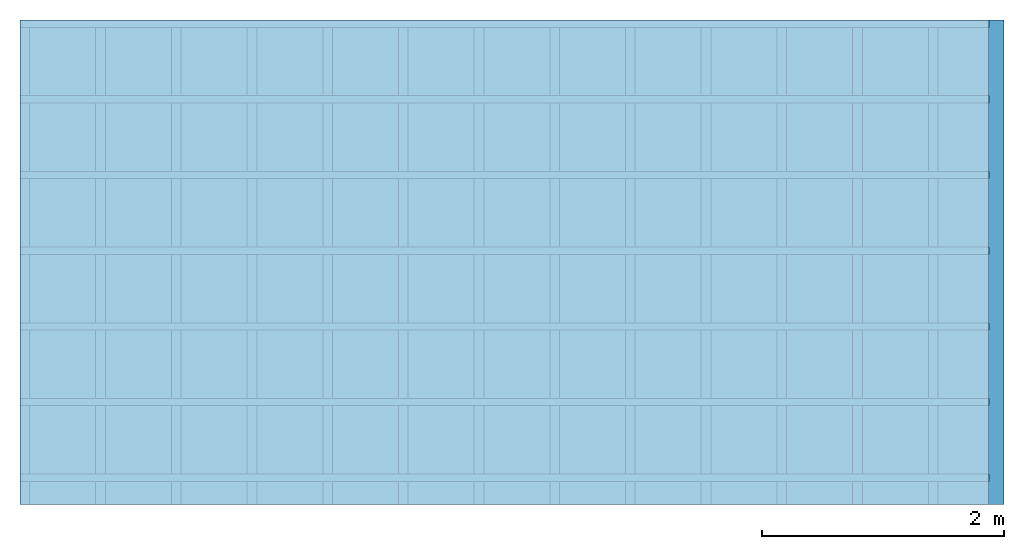
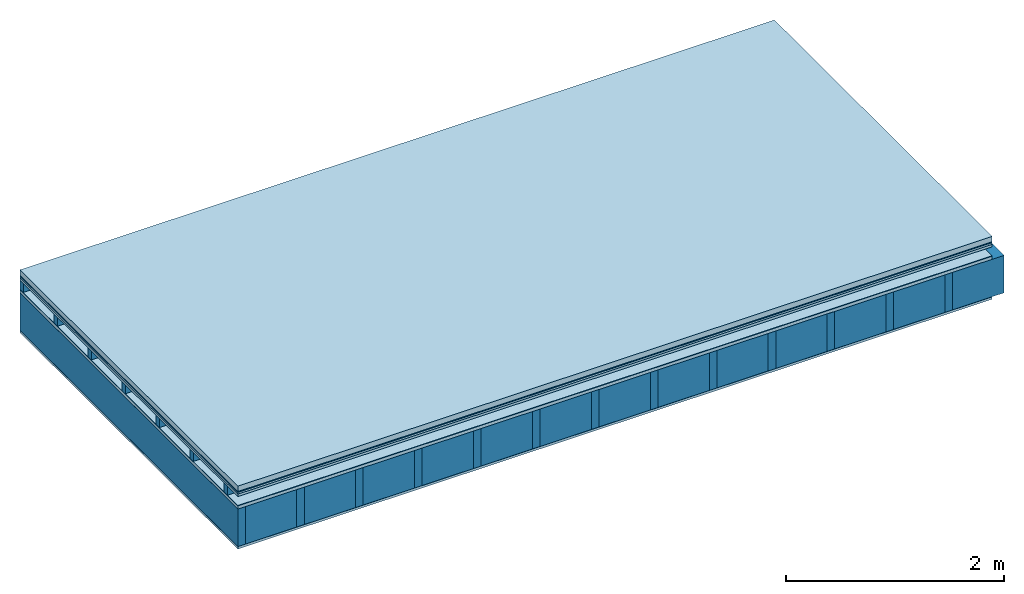
# One storey: 8 plates, 3 members, 1 element without a shape of its own.
"""IFC4 building model written with IfcOpenShell, lengths in metres."""

from ifc_helpers import new_model, si_unit, derived_unit, direction, frame, frame_2d, origin, origin_with_axes, place, context, project, spatial, rectangle, extrude, material, layer, layer_set, type_object, element, aggregate, save


model = new_model("IFC4")

# Units and contexts
plan_context = context("Plan", 3, precision=1e-05, world=origin(), true_north=direction((0.0, 1.0)))
model_context = context("Model", 3, precision=1e-05, world=origin(), true_north=direction((0.0, 1.0)))
ifc_project = project(units=[si_unit("LENGTHUNIT", "METRE"), derived_unit("SOUNDPRESSUREUNIT", [(si_unit("PRESSUREUNIT", "PASCAL", prefix="MICRO"), 0)]), si_unit("ENERGYUNIT", "JOULE", prefix="MEGA"), si_unit("MASSUNIT", "GRAM", prefix="KILO"), derived_unit("THERMALTRANSMITTANCEUNIT", [(si_unit("POWERUNIT", "WATT"), 1), (si_unit("AREAUNIT", "SQUARE_METRE"), -1), (si_unit("THERMODYNAMICTEMPERATUREUNIT", "KELVIN"), -1)]), derived_unit("AREADENSITYUNIT", [(si_unit("MASSUNIT", "GRAM", prefix="KILO"), 1), (si_unit("AREAUNIT", "SQUARE_METRE"), -1)]), derived_unit("USERDEFINED", [(si_unit("ENERGYUNIT", "JOULE", prefix="MEGA"), 1), (si_unit("AREAUNIT", "SQUARE_METRE"), -1)])], contexts=[plan_context, model_context])

# Site, building, storey
site = spatial("IfcSite", under=ifc_project)
building_placement = place(None, origin())
building = spatial("IfcBuilding", under=site, at=building_placement)
storey_placement = place(building_placement, origin())
storey = spatial("IfcBuildingStorey", under=building, at=storey_placement)

# Slab, members, plates
ifc_material_1 = material(Name="clay", Category="02.004")
ifc_layer_1 = layer(ifc_material_1, 0.06, Name="Use and protection layer 2")
ifc_material_2 = material(Name="Protective layer", Category="09.007")
ifc_layer_2 = layer(ifc_material_2, 0.01, Name="Use and protection layer 1")
ifc_material_3 = material(Name="Bituminous", Category="09.003")
ifc_layer_3 = layer(ifc_material_3, 0.02, Name="Seal")
ifc_material_4 = material(Category="07.009")
ifc_layer_4 = layer(ifc_material_4, 0.027, Name="Covering 1st layer")
ifc_layer_5 = layer(None, 0.1, Name="Battens / profiles")
ifc_material_5 = material(Name="Roofing underlay", Category="09.008")
ifc_layer_6 = layer(ifc_material_5, 0.005, Name="Under the roof")
ifc_material_6 = material(Category="10.009")
ifc_layer_7 = layer(ifc_material_6, 0.035, Name="above 2nd layer")
ifc_material_7 = material(Name="no composite action")
ifc_layer_8 = layer(ifc_material_7, 0.0, Name="Bond")
ifc_layer_9 = layer(None, 0.42, Name="Support")
ifc_material_8 = material(Name="of the art")
ifc_layer_10 = layer(ifc_material_8, 0.0, Name="Bond")
ifc_material_9 = material(Name="Vapor barrier polyethylene (PE)", Category="09.002")
ifc_layer_11 = layer(ifc_material_9, 0.001, Name="Vapor barrier")
ifc_material_10 = material(Name="3-layer panels", Category="07.001")
ifc_layer_12 = layer(ifc_material_10, 0.027, Name="Covering below 1st layer")
ifc_layer_set = layer_set([ifc_layer_1, ifc_layer_2, ifc_layer_3, ifc_layer_4, ifc_layer_5, ifc_layer_6, ifc_layer_7, ifc_layer_8, ifc_layer_9, ifc_layer_10, ifc_layer_11, ifc_layer_12])
slab_type = type_object("IfcSlabType", Name="F0110", PredefinedType="NOTDEFINED", material=ifc_layer_set)
slab_placement = place(None, frame((0.0, 0.0, 0.0), z_axis=(0.0, 0.0, -1.0), x_axis=(1.0, 0.0, 0.0)))
slab = element("IfcSlab", 1, at=slab_placement, inside=storey, type_object=slab_type, material=ifc_layer_set, Name="Slab #1")
ifc_material_11 = material()
member_1_placement = place(slab_placement, origin())
member_1 = element("IfcMember", 2, at=member_1_placement, material=ifc_material_11, Name="Battens / profiles", context=plan_context, shape_type="SweptSolid", body=[
    extrude(rectangle(XDim=0.06, YDim=0.1, at=frame_2d((0.03, 0.05), x_axis=(1.0, 0.0))), frame((0.0, 0.0, 0.117), z_axis=(1.0, 0.0, 0.0), x_axis=(0.0, 1.0, 0.0)), (0.0, 0.0, 1.0), 8.0),
    extrude(rectangle(XDim=0.06, YDim=0.1, at=frame_2d((0.03, 0.05), x_axis=(1.0, 0.0))), frame((0.0, 0.625, 0.117), z_axis=(1.0, 0.0, 0.0), x_axis=(0.0, 1.0, 0.0)), (0.0, 0.0, 1.0), 8.0),
    extrude(rectangle(XDim=0.06, YDim=0.1, at=frame_2d((0.03, 0.05), x_axis=(1.0, 0.0))), frame((0.0, 1.25, 0.117), z_axis=(1.0, 0.0, 0.0), x_axis=(0.0, 1.0, 0.0)), (0.0, 0.0, 1.0), 8.0),
    extrude(rectangle(XDim=0.06, YDim=0.1, at=frame_2d((0.03, 0.05), x_axis=(1.0, 0.0))), frame((0.0, 1.875, 0.117), z_axis=(1.0, 0.0, 0.0), x_axis=(0.0, 1.0, 0.0)), (0.0, 0.0, 1.0), 8.0),
    extrude(rectangle(XDim=0.06, YDim=0.1, at=frame_2d((0.03, 0.05), x_axis=(1.0, 0.0))), frame((0.0, 2.5, 0.117), z_axis=(1.0, 0.0, 0.0), x_axis=(0.0, 1.0, 0.0)), (0.0, 0.0, 1.0), 8.0),
    extrude(rectangle(XDim=0.06, YDim=0.1, at=frame_2d((0.03, 0.05), x_axis=(1.0, 0.0))), frame((0.0, 3.125, 0.117), z_axis=(1.0, 0.0, 0.0), x_axis=(0.0, 1.0, 0.0)), (0.0, 0.0, 1.0), 8.0),
    extrude(rectangle(XDim=0.06, YDim=0.1, at=frame_2d((0.03, 0.05), x_axis=(1.0, 0.0))), frame((0.0, 3.75, 0.117), z_axis=(1.0, 0.0, 0.0), x_axis=(0.0, 1.0, 0.0)), (0.0, 0.0, 1.0), 8.0),
])
ifc_material_12 = material()
member_2_placement = place(slab_placement, origin())
member_2 = element("IfcMember", 3, at=member_2_placement, material=ifc_material_12, Name="Support", context=plan_context, shape_type="SweptSolid", body=[
    extrude(rectangle(XDim=0.08, YDim=0.42, at=frame_2d((0.04, 0.21), x_axis=(1.0, 0.0))), frame((0.0, 4.0, 0.257), z_axis=(0.0, -1.0, 0.0), x_axis=(1.0, 0.0, 0.0)), (0.0, 0.0, 1.0), 4.0),
    extrude(rectangle(XDim=0.08, YDim=0.42, at=frame_2d((0.04, 0.21), x_axis=(1.0, 0.0))), frame((0.625, 4.0, 0.257), z_axis=(0.0, -1.0, 0.0), x_axis=(1.0, 0.0, 0.0)), (0.0, 0.0, 1.0), 4.0),
    extrude(rectangle(XDim=0.08, YDim=0.42, at=frame_2d((0.04, 0.21), x_axis=(1.0, 0.0))), frame((1.25, 4.0, 0.257), z_axis=(0.0, -1.0, 0.0), x_axis=(1.0, 0.0, 0.0)), (0.0, 0.0, 1.0), 4.0),
    extrude(rectangle(XDim=0.08, YDim=0.42, at=frame_2d((0.04, 0.21), x_axis=(1.0, 0.0))), frame((1.875, 4.0, 0.257), z_axis=(0.0, -1.0, 0.0), x_axis=(1.0, 0.0, 0.0)), (0.0, 0.0, 1.0), 4.0),
    extrude(rectangle(XDim=0.08, YDim=0.42, at=frame_2d((0.04, 0.21), x_axis=(1.0, 0.0))), frame((2.5, 4.0, 0.257), z_axis=(0.0, -1.0, 0.0), x_axis=(1.0, 0.0, 0.0)), (0.0, 0.0, 1.0), 4.0),
    extrude(rectangle(XDim=0.08, YDim=0.42, at=frame_2d((0.04, 0.21), x_axis=(1.0, 0.0))), frame((3.125, 4.0, 0.257), z_axis=(0.0, -1.0, 0.0), x_axis=(1.0, 0.0, 0.0)), (0.0, 0.0, 1.0), 4.0),
    extrude(rectangle(XDim=0.08, YDim=0.42, at=frame_2d((0.04, 0.21), x_axis=(1.0, 0.0))), frame((3.75, 4.0, 0.257), z_axis=(0.0, -1.0, 0.0), x_axis=(1.0, 0.0, 0.0)), (0.0, 0.0, 1.0), 4.0),
    extrude(rectangle(XDim=0.08, YDim=0.42, at=frame_2d((0.04, 0.21), x_axis=(1.0, 0.0))), frame((4.375, 4.0, 0.257), z_axis=(0.0, -1.0, 0.0), x_axis=(1.0, 0.0, 0.0)), (0.0, 0.0, 1.0), 4.0),
    extrude(rectangle(XDim=0.08, YDim=0.42, at=frame_2d((0.04, 0.21), x_axis=(1.0, 0.0))), frame((5.0, 4.0, 0.257), z_axis=(0.0, -1.0, 0.0), x_axis=(1.0, 0.0, 0.0)), (0.0, 0.0, 1.0), 4.0),
    extrude(rectangle(XDim=0.08, YDim=0.42, at=frame_2d((0.04, 0.21), x_axis=(1.0, 0.0))), frame((5.625, 4.0, 0.257), z_axis=(0.0, -1.0, 0.0), x_axis=(1.0, 0.0, 0.0)), (0.0, 0.0, 1.0), 4.0),
    extrude(rectangle(XDim=0.08, YDim=0.42, at=frame_2d((0.04, 0.21), x_axis=(1.0, 0.0))), frame((6.25, 4.0, 0.257), z_axis=(0.0, -1.0, 0.0), x_axis=(1.0, 0.0, 0.0)), (0.0, 0.0, 1.0), 4.0),
    extrude(rectangle(XDim=0.08, YDim=0.42, at=frame_2d((0.04, 0.21), x_axis=(1.0, 0.0))), frame((6.875, 4.0, 0.257), z_axis=(0.0, -1.0, 0.0), x_axis=(1.0, 0.0, 0.0)), (0.0, 0.0, 1.0), 4.0),
    extrude(rectangle(XDim=0.08, YDim=0.42, at=frame_2d((0.04, 0.21), x_axis=(1.0, 0.0))), frame((7.5, 4.0, 0.257), z_axis=(0.0, -1.0, 0.0), x_axis=(1.0, 0.0, 0.0)), (0.0, 0.0, 1.0), 4.0),
])
ifc_material_13 = material()
member_3_placement = place(slab_placement, origin())
member_3 = element("IfcMember", 4, at=member_3_placement, material=ifc_material_13, Name="Cavity", context=plan_context, shape_type="SweptSolid", body=[
    extrude(rectangle(XDim=0.545, YDim=0.42, at=frame_2d((0.2725, 0.21), x_axis=(1.0, 0.0))), frame((0.08, 4.0, 0.257), z_axis=(0.0, -1.0, 0.0), x_axis=(1.0, 0.0, 0.0)), (0.0, 0.0, 1.0), 4.0),
    extrude(rectangle(XDim=0.545, YDim=0.42, at=frame_2d((0.2725, 0.21), x_axis=(1.0, 0.0))), frame((0.705, 4.0, 0.257), z_axis=(0.0, -1.0, 0.0), x_axis=(1.0, 0.0, 0.0)), (0.0, 0.0, 1.0), 4.0),
    extrude(rectangle(XDim=0.545, YDim=0.42, at=frame_2d((0.2725, 0.21), x_axis=(1.0, 0.0))), frame((1.33, 4.0, 0.257), z_axis=(0.0, -1.0, 0.0), x_axis=(1.0, 0.0, 0.0)), (0.0, 0.0, 1.0), 4.0),
    extrude(rectangle(XDim=0.545, YDim=0.42, at=frame_2d((0.2725, 0.21), x_axis=(1.0, 0.0))), frame((1.955, 4.0, 0.257), z_axis=(0.0, -1.0, 0.0), x_axis=(1.0, 0.0, 0.0)), (0.0, 0.0, 1.0), 4.0),
    extrude(rectangle(XDim=0.545, YDim=0.42, at=frame_2d((0.2725, 0.21), x_axis=(1.0, 0.0))), frame((2.58, 4.0, 0.257), z_axis=(0.0, -1.0, 0.0), x_axis=(1.0, 0.0, 0.0)), (0.0, 0.0, 1.0), 4.0),
    extrude(rectangle(XDim=0.545, YDim=0.42, at=frame_2d((0.2725, 0.21), x_axis=(1.0, 0.0))), frame((3.205, 4.0, 0.257), z_axis=(0.0, -1.0, 0.0), x_axis=(1.0, 0.0, 0.0)), (0.0, 0.0, 1.0), 4.0),
    extrude(rectangle(XDim=0.545, YDim=0.42, at=frame_2d((0.2725, 0.21), x_axis=(1.0, 0.0))), frame((3.83, 4.0, 0.257), z_axis=(0.0, -1.0, 0.0), x_axis=(1.0, 0.0, 0.0)), (0.0, 0.0, 1.0), 4.0),
    extrude(rectangle(XDim=0.545, YDim=0.42, at=frame_2d((0.2725, 0.21), x_axis=(1.0, 0.0))), frame((4.455, 4.0, 0.257), z_axis=(0.0, -1.0, 0.0), x_axis=(1.0, 0.0, 0.0)), (0.0, 0.0, 1.0), 4.0),
    extrude(rectangle(XDim=0.545, YDim=0.42, at=frame_2d((0.2725, 0.21), x_axis=(1.0, 0.0))), frame((5.08, 4.0, 0.257), z_axis=(0.0, -1.0, 0.0), x_axis=(1.0, 0.0, 0.0)), (0.0, 0.0, 1.0), 4.0),
    extrude(rectangle(XDim=0.545, YDim=0.42, at=frame_2d((0.2725, 0.21), x_axis=(1.0, 0.0))), frame((5.705, 4.0, 0.257), z_axis=(0.0, -1.0, 0.0), x_axis=(1.0, 0.0, 0.0)), (0.0, 0.0, 1.0), 4.0),
    extrude(rectangle(XDim=0.545, YDim=0.42, at=frame_2d((0.2725, 0.21), x_axis=(1.0, 0.0))), frame((6.33, 4.0, 0.257), z_axis=(0.0, -1.0, 0.0), x_axis=(1.0, 0.0, 0.0)), (0.0, 0.0, 1.0), 4.0),
    extrude(rectangle(XDim=0.545, YDim=0.42, at=frame_2d((0.2725, 0.21), x_axis=(1.0, 0.0))), frame((6.955, 4.0, 0.257), z_axis=(0.0, -1.0, 0.0), x_axis=(1.0, 0.0, 0.0)), (0.0, 0.0, 1.0), 4.0),
    extrude(rectangle(XDim=0.545, YDim=0.42, at=frame_2d((0.2725, 0.21), x_axis=(1.0, 0.0))), frame((7.58, 4.0, 0.257), z_axis=(0.0, -1.0, 0.0), x_axis=(1.0, 0.0, 0.0)), (0.0, 0.0, 1.0), 4.0),
])
plate_1_placement = place(slab_placement, origin())
plate_1 = element("IfcPlate", 5, at=plate_1_placement, material=ifc_material_1, Name="Use and protection layer 2", context=plan_context, shape_type="SweptSolid", body=[
    extrude(rectangle(XDim=8.0, YDim=4.0, at=frame_2d((4.0, 2.0), x_axis=(1.0, 0.0))), origin_with_axes(), (0.0, 0.0, 1.0), 0.06),
])
plate_2_placement = place(slab_placement, origin())
plate_2 = element("IfcPlate", 6, at=plate_2_placement, material=ifc_material_2, Name="Use and protection layer 1", context=plan_context, shape_type="SweptSolid", body=[
    extrude(rectangle(XDim=8.0, YDim=4.0, at=frame_2d((4.0, 2.0), x_axis=(1.0, 0.0))), frame((0.0, 0.0, 0.06), z_axis=(0.0, 0.0, 1.0), x_axis=(1.0, 0.0, 0.0)), (0.0, 0.0, 1.0), 0.01),
])
plate_3_placement = place(slab_placement, origin())
plate_3 = element("IfcPlate", 7, at=plate_3_placement, material=ifc_material_3, Name="Seal", context=plan_context, shape_type="SweptSolid", body=[
    extrude(rectangle(XDim=8.0, YDim=4.0, at=frame_2d((4.0, 2.0), x_axis=(1.0, 0.0))), frame((0.0, 0.0, 0.07), z_axis=(0.0, 0.0, 1.0), x_axis=(1.0, 0.0, 0.0)), (0.0, 0.0, 1.0), 0.02),
])
plate_4_placement = place(slab_placement, origin())
plate_4 = element("IfcPlate", 8, at=plate_4_placement, material=ifc_material_4, Name="Covering 1st layer", context=plan_context, shape_type="SweptSolid", body=[
    extrude(rectangle(XDim=8.0, YDim=4.0, at=frame_2d((4.0, 2.0), x_axis=(1.0, 0.0))), frame((0.0, 0.0, 0.09), z_axis=(0.0, 0.0, 1.0), x_axis=(1.0, 0.0, 0.0)), (0.0, 0.0, 1.0), 0.027),
])
plate_5_placement = place(slab_placement, origin())
plate_5 = element("IfcPlate", 9, at=plate_5_placement, material=ifc_material_5, Name="Under the roof", context=plan_context, shape_type="SweptSolid", body=[
    extrude(rectangle(XDim=8.0, YDim=4.0, at=frame_2d((4.0, 2.0), x_axis=(1.0, 0.0))), frame((0.0, 0.0, 0.217), z_axis=(0.0, 0.0, 1.0), x_axis=(1.0, 0.0, 0.0)), (0.0, 0.0, 1.0), 0.005),
])
plate_6_placement = place(slab_placement, origin())
plate_6 = element("IfcPlate", 10, at=plate_6_placement, material=ifc_material_6, Name="above 2nd layer", context=plan_context, shape_type="SweptSolid", body=[
    extrude(rectangle(XDim=8.0, YDim=4.0, at=frame_2d((4.0, 2.0), x_axis=(1.0, 0.0))), frame((0.0, 0.0, 0.222), z_axis=(0.0, 0.0, 1.0), x_axis=(1.0, 0.0, 0.0)), (0.0, 0.0, 1.0), 0.035),
])
plate_7_placement = place(slab_placement, origin())
plate_7 = element("IfcPlate", 11, at=plate_7_placement, material=ifc_material_9, Name="Vapor barrier", context=plan_context, shape_type="SweptSolid", body=[
    extrude(rectangle(XDim=8.0, YDim=4.0, at=frame_2d((4.0, 2.0), x_axis=(1.0, 0.0))), frame((0.0, 0.0, 0.677), z_axis=(0.0, 0.0, 1.0), x_axis=(1.0, 0.0, 0.0)), (0.0, 0.0, 1.0), 0.001),
])
plate_8_placement = place(slab_placement, origin())
plate_8 = element("IfcPlate", 12, at=plate_8_placement, material=ifc_material_10, Name="Covering below 1st layer", context=plan_context, shape_type="SweptSolid", body=[
    extrude(rectangle(XDim=8.0, YDim=4.0, at=frame_2d((4.0, 2.0), x_axis=(1.0, 0.0))), frame((0.0, 0.0, 0.678), z_axis=(0.0, 0.0, 1.0), x_axis=(1.0, 0.0, 0.0)), (0.0, 0.0, 1.0), 0.027),
])
aggregate(slab, [plate_1, plate_2, plate_3, plate_4, member_1, plate_5, plate_6, member_2, member_3, plate_7, plate_8])

save(model, "model.ifc")
